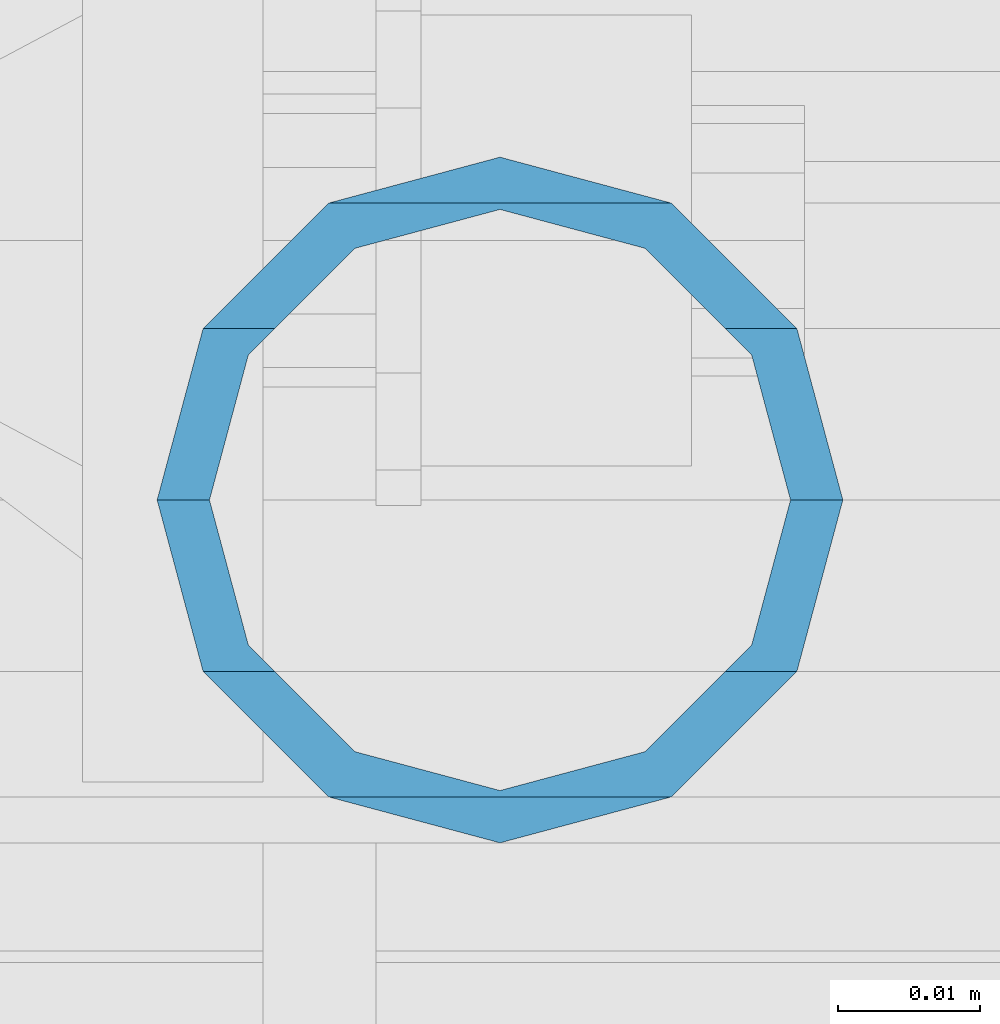
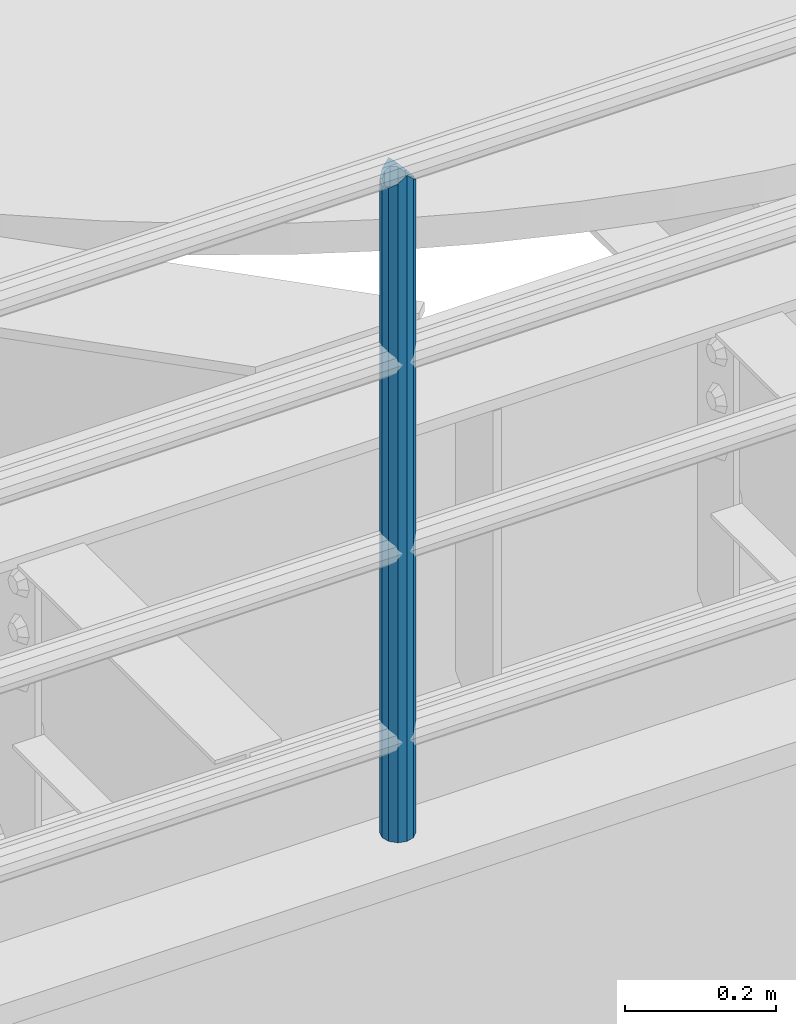
# One storey, part 612 of 1876: 1 column, 1 element without a shape of its own.
"""IFC2X3 building model written with IfcOpenShell, lengths in millimetres."""

import ifcopenshell
import ifcopenshell.guid

model = None  # the IFC model being written
_history = None  # IfcOwnerHistory: only IFC2X3 demands one
_inside = {}  # id of a spatial element -> (the spatial element, [elements in it])
_under = {}  # id of a project, library or spatial element -> (it, [spatial elements below it])
_declared = {}  # id of a project -> (the project, [libraries it declares])
_typed = {}  # id of a type object -> (the type object, [elements of that type])
_made_of = {}  # id of a material, layer set ... -> (it, [elements and type objects made of it])


def new_model(schema):
    """Start an empty IFC model of exactly this schema.

    Asked for "IFC4X3", IfcOpenShell would pick the latest addendum, in which some entities
    have other attributes; the version numbers below select the first issue.
    IFC2X3 requires an IfcOwnerHistory on every rooted entity: one is made here for all.
    """
    global model, _history
    if schema == "IFC4X3":
        model = ifcopenshell.file(schema_version=(4, 3, 0, 0))
    else:
        model = ifcopenshell.file(schema=schema)
    _inside.clear()
    _under.clear()
    _declared.clear()
    _typed.clear()
    _made_of.clear()
    _history = None
    if model.schema == "IFC2X3":
        org = make("IfcOrganization", Name="unknown")
        user = make(
            "IfcPersonAndOrganization",
            ThePerson=make("IfcPerson", FamilyName="unknown"),
            TheOrganization=org,
        )
        app = make(
            "IfcApplication",
            ApplicationDeveloper=org,
            Version="unknown",
            ApplicationFullName="unknown",
            ApplicationIdentifier="unknown",
        )
        _history = make(
            "IfcOwnerHistory",
            OwningUser=user,
            OwningApplication=app,
            ChangeAction="ADDED",
            CreationDate=0,
        )
    return model


def make(cls, **values):
    """One entity of the class cls with the attributes given. An attribute that is None is left unset."""
    return model.create_entity(
        cls, **{name: value for name, value in values.items() if value is not None}
    )


def rooted(cls, **values):
    """An entity with a GlobalId (a new one), such as an element, a storey or a relation."""
    return make(cls, GlobalId=ifcopenshell.guid.new(), OwnerHistory=_history, **values)


def si_unit(unit_type, name, prefix=None):
    """IfcSIUnit, for example si_unit("LENGTHUNIT", "METRE", prefix="MILLI")."""
    return make("IfcSIUnit", UnitType=unit_type, Prefix=prefix, Name=name)


def assignment(units):
    """IfcUnitAssignment: the units of a project."""
    return None if units is None else make("IfcUnitAssignment", Units=units)


def point(xyz):
    """IfcCartesianPoint."""
    return None if xyz is None else make("IfcCartesianPoint", Coordinates=xyz)


def direction(xyz):
    """IfcDirection."""
    return None if xyz is None else make("IfcDirection", DirectionRatios=xyz)


def frame(location, z_axis=None, x_axis=None):
    """IfcAxis2Placement3D, a coordinate frame: its origin and axes. An axis left out is left unset."""
    return make(
        "IfcAxis2Placement3D",
        Location=point(location),
        Axis=direction(z_axis),
        RefDirection=direction(x_axis),
    )


def origin_with_axes():
    """The frame at (0, 0, 0) with the z axis (0, 0, 1) and the x axis (1, 0, 0) written out."""
    return frame((0.0, 0.0, 0.0), z_axis=(0.0, 0.0, 1.0), x_axis=(1.0, 0.0, 0.0))


def place(relative_to, where):
    """IfcLocalPlacement: puts the frame where relative to a parent placement (None: the world)."""
    return make(
        "IfcLocalPlacement", PlacementRelTo=relative_to, RelativePlacement=where
    )


def context(
    kind, dimensions, precision=None, world=None, true_north=None, identifier=None
):
    """IfcGeometricRepresentationContext, for example the 3D "Model" context."""
    return make(
        "IfcGeometricRepresentationContext",
        ContextIdentifier=identifier,
        ContextType=kind,
        CoordinateSpaceDimension=dimensions,
        Precision=precision,
        WorldCoordinateSystem=world,
        TrueNorth=true_north,
    )


def subcontext(parent, identifier, kind, view, scale=None):
    """IfcGeometricRepresentationSubContext, for example "Body" below "Model"."""
    return make(
        "IfcGeometricRepresentationSubContext",
        ContextIdentifier=identifier,
        ContextType=kind,
        ParentContext=parent,
        TargetScale=scale,
        TargetView=view,
    )


def project(units=None, contexts=None):
    """IfcProject with its units and contexts."""
    return rooted(
        "IfcProject",
        Name="project",
        RepresentationContexts=contexts,
        UnitsInContext=assignment(units),
    )


def spatial(cls, under=None, at=None, **own):
    """A site, building, storey or space (cls), placed at a placement, below another one or the project."""
    s = rooted(cls, ObjectPlacement=at, **own)
    if under is not None:
        _under.setdefault(under.id(), (under, []))[1].append(s)
    return s


def faces_of(points, faces, orient=None, outer=None):
    """IfcFace entities. A face is a list of loops; a loop is a list of indices into points, from 0.

    orient and outer hold one flag for each loop. By default every Orientation is true, the
    first loop of a face is its IfcFaceOuterBound and the others are IfcFaceBound.
    """
    made = []
    for i, loops in enumerate(faces):
        bounds = []
        for j, loop in enumerate(loops):
            is_outer = j == 0 if outer is None else outer[i][j]
            bounds.append(
                make(
                    "IfcFaceOuterBound" if is_outer else "IfcFaceBound",
                    Bound=make("IfcPolyLoop", Polygon=[points[k] for k in loop]),
                    Orientation=True if orient is None else orient[i][j],
                )
            )
        made.append(make("IfcFace", Bounds=bounds))
    return made


def faceted_brep(points, faces, orient=None, outer=None, voids=None):
    """IfcFacetedBrep: a solid bounded by flat faces; with voids (closed shells), ...WithVoids."""
    shared = [point(p) for p in points]
    hull = make("IfcClosedShell", CfsFaces=faces_of(shared, faces, orient, outer))
    if voids is None:
        return make("IfcFacetedBrep", Outer=hull)
    return make(
        "IfcFacetedBrepWithVoids",
        Outer=hull,
        Voids=[
            make(cls, CfsFaces=faces_of(shared, fs, o, b)) for cls, fs, o, b in voids
        ],
    )


def shape(context_of_items, identifier, shape_type, items):
    """IfcShapeRepresentation: the items that make up one representation, for example the "Body"."""
    return make(
        "IfcShapeRepresentation",
        ContextOfItems=context_of_items,
        RepresentationIdentifier=identifier,
        RepresentationType=shape_type,
        Items=items,
    )


def material(Name=None, Category=None):
    """IfcMaterial."""
    return make("IfcMaterial", Name=Name, Category=Category)


def made_of(thing, what):
    """Note that an element or type object is made of a material, layer set ...; save() writes the relation."""
    if what is not None:
        _made_of.setdefault(what.id(), (what, []))[1].append(thing)
    return thing


def type_object(cls, material=None, **own):
    """A type object (cls), such as IfcWallType, which elements share."""
    return made_of(rooted(cls, **own), material)


def element(
    cls,
    number,
    at=None,
    inside=None,
    cuts=None,
    type_object=None,
    material=None,
    context=None,
    identifier="Body",
    shape_type=None,
    held_by="IfcProductDefinitionShape",
    body=None,
    shapes=None,
    **own,
):
    """One element of the class cls, such as IfcWall. Its Tag is "e" and its number.

    at: its placement. inside: the storey or other place that contains it. cuts: it is an
    opening in that element (IfcRelVoidsElement). A single representation is given by context,
    identifier, shape_type and body (its items); several are given by shapes. held_by: the class
    of the entity that holds the representations. save() writes the other relations.
    """
    e = rooted(cls, Tag="e%d" % number, ObjectPlacement=at, **own)
    if body is not None:
        shapes = [shape(context, identifier, shape_type, body)]
    if shapes is not None:
        e.Representation = make(held_by, Representations=shapes)
    if inside is not None:
        _inside.setdefault(inside.id(), (inside, []))[1].append(e)
    if cuts is not None:
        rooted(
            "IfcRelVoidsElement", RelatingBuildingElement=cuts, RelatedOpeningElement=e
        )
    if type_object is not None:
        _typed.setdefault(type_object.id(), (type_object, []))[1].append(e)
    return made_of(e, material)


def aggregate(whole, parts):
    """IfcRelAggregates: a whole, such as a stair, and the parts it consists of."""
    return rooted("IfcRelAggregates", RelatingObject=whole, RelatedObjects=parts)


def save(model, path):
    """Write the relations noted so far, then the file.

    IfcRelAggregates (storeys below a building ...), IfcRelContainedInSpatialStructure (elements
    in a storey), IfcRelDefinesByType, IfcRelAssociatesMaterial and IfcRelDeclares: one each for
    every whole, place, type object, material and project.
    """
    for whole, parts in _under.values():
        aggregate(whole, parts)
    for where, things in _inside.values():
        rooted(
            "IfcRelContainedInSpatialStructure",
            RelatedElements=things,
            RelatingStructure=where,
        )
    for kind, things in _typed.values():
        rooted("IfcRelDefinesByType", RelatedObjects=things, RelatingType=kind)
    for what, things in _made_of.values():
        rooted("IfcRelAssociatesMaterial", RelatedObjects=things, RelatingMaterial=what)
    for by, libraries in _declared.values():
        rooted("IfcRelDeclares", RelatingContext=by, RelatedDefinitions=libraries)
    model.write(path)


model = new_model("IFC2X3")

# Units and contexts
model_context = context("Model", 3, precision=1e-05, world=origin_with_axes())
body_context = subcontext(model_context, "Body", "Model", "MODEL_VIEW")
ifc_project = project(units=[si_unit("LENGTHUNIT", "METRE", prefix="MILLI"), si_unit("AREAUNIT", "SQUARE_METRE"), si_unit("VOLUMEUNIT", "CUBIC_METRE"), si_unit("MASSUNIT", "GRAM", prefix="KILO"), si_unit("TIMEUNIT", "SECOND"), si_unit("PLANEANGLEUNIT", "RADIAN"), si_unit("SOLIDANGLEUNIT", "STERADIAN"), si_unit("THERMODYNAMICTEMPERATUREUNIT", "DEGREE_CELSIUS"), si_unit("LUMINOUSINTENSITYUNIT", "LUMEN")], contexts=[model_context])

# Site, building, storey
site_placement = place(None, origin_with_axes())
site = spatial("IfcSite", under=ifc_project, at=site_placement, CompositionType="ELEMENT")
building_placement = place(site_placement, origin_with_axes())
building = spatial("IfcBuilding", under=site, at=building_placement, Name="Undefined", CompositionType="ELEMENT")
storey_placement = place(building_placement, origin_with_axes())
storey = spatial("IfcBuildingStorey", under=building, at=storey_placement, Name="Undefined", CompositionType="ELEMENT", Elevation=0.0)

# Assembly, column
assembly_placement = place(storey_placement, origin_with_axes())
assembly = element("IfcElementAssembly", 1, at=assembly_placement, inside=storey, Name="RAIL", AssemblyPlace="NOTDEFINED", PredefinedType="RIGID_FRAME")
ifc_material = material()
column_type = type_object("IfcColumnType", Name="PIPE1-1/2SCH40", PredefinedType="NOTDEFINED")
column_placement = place(assembly_placement, frame((2870.19999998823, -4654.55000114554, 8153.4), z_axis=(0.0, 1.0, 0.0), x_axis=(0.0, 0.0, 1.0)))
column = element("IfcColumn", 2, at=column_placement, type_object=column_type, material=ifc_material, Name="POST", ObjectType="PIPE1-1/2SCH40", context=body_context, shape_type="Brep", body=[
    faceted_brep([(1076.325, 0.0, -24.1300000000001), (1064.26, 12.065, -20.8971929933186), (1064.26, -12.0650000000001, -20.8971929933186), (1054.93437856882, 17.7076214311801, 10.2235000000001), (1052.195, 20.4470000000001, 0.0), (1052.195, 24.13, 0.0), (1055.42780700668, 20.8971929933185, 12.0649999999996), (1055.42780700668, 15.8661214311869, 12.0649999999932), (1055.42780700668, 15.8661214311742, -12.065000000006), (1055.42780700668, 20.8971929933185, -12.0649999999996), (1054.93437856882, 17.7076214311801, -10.2235000000001), (1061.07042843786, 10.2235000000001, -17.7076214311801), (1063.80980700668, 0.0, -20.4470000000001), (1061.07042843786, -10.2235000000001, -17.7076214311801), (1055.42780700668, -15.8661214311742, -12.065000000006), (1055.42780700668, -20.8971929933184, -12.0649999999996), (1054.93437856882, -17.7076214311801, -10.2235000000001), (1052.195, -20.4470000000001, 0.0), (1052.195, -24.1300000000001, 0.0), (1054.93437856882, -17.7076214311801, 10.2235000000001), (1055.42780700668, -15.8661214311869, 12.0649999999932), (1055.42780700668, -20.8971929933184, 12.0649999999996), (1076.325, 0.0, 24.1300000000001), (1064.26, -12.0650000000001, 20.8971929933186), (1064.26, 12.065, 20.8971929933186), (1061.07042843787, -10.2235000000001, 17.7076214311801), (1063.80980700669, 0.0, 20.4470000000001), (1061.07042843787, 10.2235000000001, 17.7076214311801), (0.0, -20.8971929933184, -12.0649999999996), (0.0, -12.0650000000001, -20.8971929933186), (-1.45519152283669e-11, 0.0, -24.130000000001), (0.0, 12.0650000000001, -20.8971929933186), (0.0, 20.8971929933184, -12.0649999999996), (0.0, 24.1299999999992, 0.0), (0.0, 20.8971929933184, 12.0649999999996), (0.0, 12.0650000000001, 20.8971929933186), (-1.45519152283669e-11, 0.0, 24.130000000001), (0.0, -20.8971929933184, 12.0649999999996), (0.0, -24.1299999999992, 0.0), (0.0, -12.0650000000001, 20.8971929933186), (0.0, -17.7076214311803, -10.2235000000001), (0.0, -10.2235000000001, -17.7076214311801), (-1.45519152283669e-11, 0.0, -20.4470000000001), (0.0, 10.2235000000001, -17.7076214311801), (0.0, 17.7076214311803, -10.2235000000001), (0.0, 20.4469999999999, 0.0), (0.0, 17.7076214311803, 10.2235000000001), (0.0, 10.2235000000001, 17.7076214311801), (-1.45519152283669e-11, 0.0, 20.4470000000001), (0.0, -10.2235000000001, 17.7076214311801), (0.0, -17.7076214311803, 10.2235000000001), (0.0, -20.4469999999999, 0.0)], [[[0, 1, 2]], [[3, 4, 5, 6, 7]], [[8, 9, 5, 4, 10]], [[2, 1, 9, 8, 11, 12, 13, 14, 15]], [[15, 14, 16, 17, 18]], [[18, 17, 19, 20, 21]], [[22, 23, 24]], [[21, 20, 25, 26, 27, 7, 6, 24, 23]], [[28, 29, 2, 15]], [[29, 30, 0, 2]], [[30, 31, 1, 0]], [[31, 32, 9, 1]], [[32, 33, 5, 9]], [[33, 34, 6, 5]], [[34, 35, 24, 6]], [[35, 36, 22, 24]], [[37, 38, 18, 21]], [[39, 37, 21, 23]], [[36, 39, 23, 22]], [[38, 28, 15, 18]], [[37, 39, 36, 35, 34, 33, 32, 31, 30, 29, 28, 38], [40, 41, 42, 43, 44, 45, 46, 47, 48, 49, 50, 51]], [[49, 48, 26, 25]], [[19, 50, 49, 25, 20]], [[51, 50, 19, 17]], [[40, 51, 17, 16]], [[41, 40, 16, 14, 13]], [[42, 41, 13, 12]], [[43, 42, 12, 11]], [[10, 44, 43, 11, 8]], [[45, 44, 10, 4]], [[46, 45, 4, 3]], [[47, 46, 3, 7, 27]], [[48, 47, 27, 26]]]),
])
aggregate(assembly, [column])

save(model, "model.ifc")
